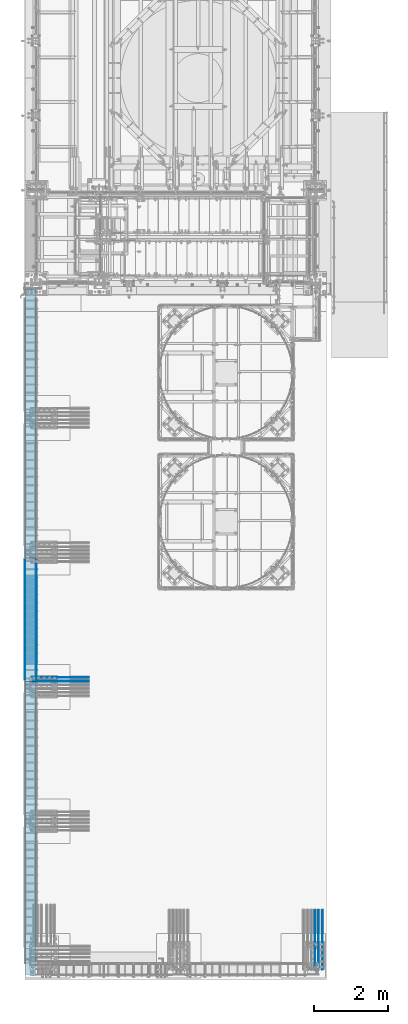
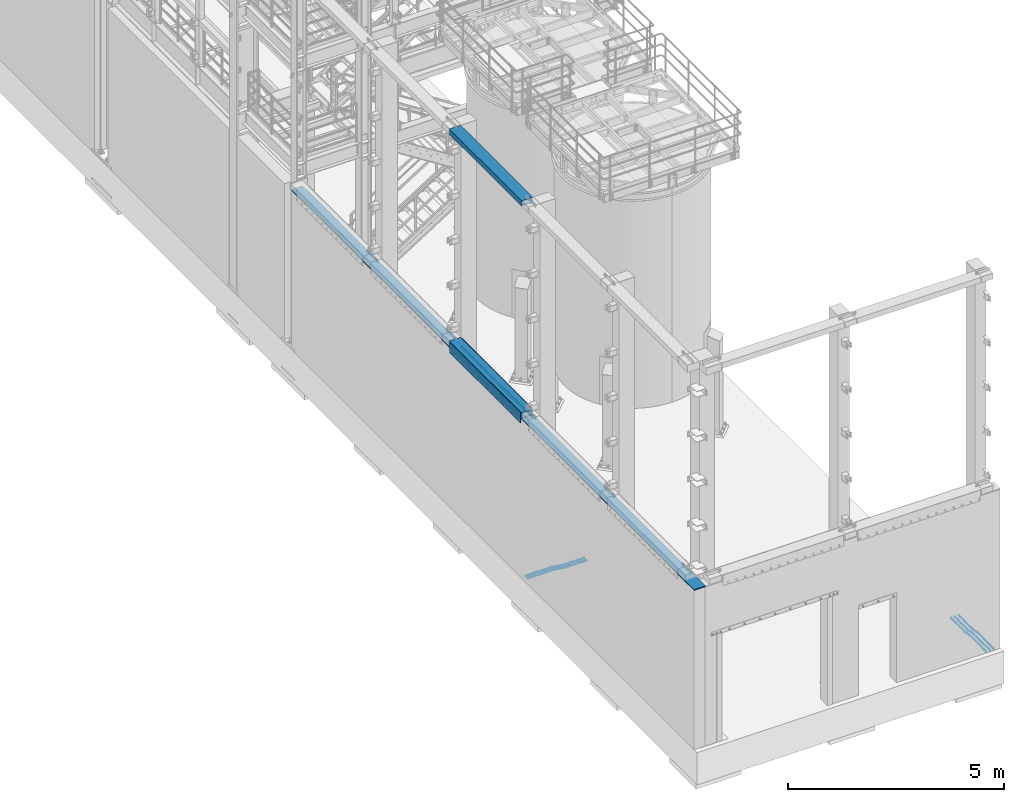
# One storey, part 912 of 1876: 11 beams, 6 elements without a shape of their own.
"""IFC2X3 building model written with IfcOpenShell, lengths in millimetres."""

from ifc_helpers import new_model, si_unit, frame, origin_with_axes, place, context, subcontext, project, spatial, faceted_brep, material, type_object, element, aggregate, save


model = new_model("IFC2X3")

# Units and contexts
model_context = context("Model", 3, precision=1e-05, world=origin_with_axes())
body_context = subcontext(model_context, "Body", "Model", "MODEL_VIEW")
ifc_project = project(units=[si_unit("LENGTHUNIT", "METRE", prefix="MILLI"), si_unit("AREAUNIT", "SQUARE_METRE"), si_unit("VOLUMEUNIT", "CUBIC_METRE"), si_unit("MASSUNIT", "GRAM", prefix="KILO"), si_unit("TIMEUNIT", "SECOND"), si_unit("PLANEANGLEUNIT", "RADIAN"), si_unit("SOLIDANGLEUNIT", "STERADIAN"), si_unit("THERMODYNAMICTEMPERATUREUNIT", "DEGREE_CELSIUS"), si_unit("LUMINOUSINTENSITYUNIT", "LUMEN")], contexts=[model_context])

# Site, building, storey
site_placement = place(None, origin_with_axes())
site = spatial("IfcSite", under=ifc_project, at=site_placement, CompositionType="ELEMENT")
building_placement = place(site_placement, origin_with_axes())
building = spatial("IfcBuilding", under=site, at=building_placement, Name="Undefined", CompositionType="ELEMENT")
storey_placement = place(building_placement, origin_with_axes())
storey = spatial("IfcBuildingStorey", under=building, at=storey_placement, Name="Undefined", CompositionType="ELEMENT", Elevation=0.0)

# Assembly, beam
assembly_1_placement = place(storey_placement, origin_with_axes())
assembly_1 = element("IfcElementAssembly", 1, at=assembly_1_placement, inside=storey, Name="BEAM", AssemblyPlace="NOTDEFINED", PredefinedType="RIGID_FRAME")
ifc_material_1 = material()
beam_type_1 = type_object("IfcBeamType", Name="HSS12X6X1/2", PredefinedType="NOTDEFINED")
beam_1_placement = place(assembly_1_placement, frame((-139.7, -17932.4, 10591.8), z_axis=(-1.0, 0.0, 0.0), x_axis=(0.0, 1.0, 0.0)))
beam_1 = element("IfcBeam", 2, at=beam_1_placement, type_object=beam_type_1, material=ifc_material_1, Name="BEAM", ObjectType="HSS12X6X1/2", context=body_context, shape_type="Brep", body=[
    faceted_brep([(0.0, -63.5, -139.7), (0.0, -76.2000000000007, -139.699999999812), (0.0, -76.2000000000007, 139.700000000026), (0.0, -63.5, 139.7), (0.0, 76.2000000000007, 139.700000000026), (0.0, 63.5, 139.7), (12.6999999999734, -76.2000000000007, 152.4), (12.6999999999734, 76.2000000000007, 152.4), (0.0, 76.2000000000007, -139.699999999812), (0.0, 63.5, -139.7), (12.7000000000025, -76.2000000000007, -152.4), (12.7000000000025, 76.2000000000007, -152.4), (3340.1, 76.2000000000007, -152.4), (3340.1, -76.2000000000007, -152.4), (3352.8, -63.5, -139.7), (3352.8, 63.5, -139.7), (3352.8, 76.2000000000007, -139.7), (3352.8, -76.2000000000007, -139.7), (3352.8, -76.2000000000007, 139.7), (3340.1, -76.2000000000007, 152.4), (3340.1, 76.2000000000007, 152.4), (3352.8, 76.2000000000007, 139.7), (3352.8, 63.5, 139.7), (3352.8, -63.5, 139.7)], [[[0, 1, 2, 3]], [[4, 5, 3, 2, 6, 7]], [[8, 9, 5, 4]], [[10, 11, 12, 13]], [[0, 9, 8, 11, 10, 1]], [[9, 0, 14, 15]], [[12, 16, 15, 14, 17, 13]], [[6, 2, 1, 10, 13, 17, 18, 19]], [[7, 6, 19, 20]], [[16, 12, 11, 8, 4, 7, 20, 21]], [[15, 16, 21, 22]], [[5, 9, 15, 22]], [[3, 5, 22, 23]], [[0, 3, 23, 14]], [[17, 14, 23, 18]], [[22, 21, 20, 19, 18, 23]]]),
])
aggregate(assembly_1, [beam_1])

assembly_2_placement = place(storey_placement, origin_with_axes())
assembly_2 = element("IfcElementAssembly", 3, at=assembly_2_placement, inside=storey, Name="BEAM", AssemblyPlace="NOTDEFINED", PredefinedType="RIGID_FRAME")
beam_2_placement = place(assembly_2_placement, frame((-139.7, -17932.4, 4597.4), z_axis=(-1.0, 0.0, 0.0), x_axis=(0.0, 1.0, 0.0)))
beam_2 = element("IfcBeam", 4, at=beam_2_placement, type_object=beam_type_1, material=ifc_material_1, Name="BEAM", ObjectType="HSS12X6X1/2", context=body_context, shape_type="Brep", body=[
    faceted_brep([(0.0, -63.5, 139.7), (0.0, 63.5, 139.7), (3352.8, 63.5, 139.7), (3352.8, -63.5, 139.7), (0.0, 76.2000000000007, -139.699999999812), (0.0, 63.5, -139.7), (0.0, 76.2000000000007, 139.700000000026), (0.0, -63.5, -139.7), (12.6998385541701, 76.2000000000007, -152.4), (12.6998385541701, -76.2000000000007, -152.4), (0.0, -76.2000000000007, -139.699999999812), (0.0, -76.2000000000007, 139.700000000026), (12.6999999999734, -76.2000000000007, 152.4), (12.6999999999734, 76.2000000000007, 152.4), (3340.1, -76.2000000000007, 152.4), (3340.1, 76.2000000000007, 152.4), (3352.8, 76.2000000000007, 139.7), (3352.8, -76.2000000000007, 139.7), (3352.8, -76.2000000000007, -139.7), (3352.8, -63.5, -139.7), (3352.8, 63.5, -139.7), (3352.8, 76.2000000000007, -139.7), (3340.10010842724, 76.1999999999998, -152.4), (3340.10010842724, -76.1999999999998, -152.4)], [[[0, 1, 2, 3]], [[4, 5, 1, 6]], [[7, 5, 4, 8, 9, 10]], [[7, 10, 11, 0]], [[6, 1, 0, 11, 12, 13]], [[13, 12, 14, 15]], [[2, 16, 15, 14, 17, 3]], [[18, 19, 3, 17]], [[7, 0, 3, 19]], [[5, 7, 19, 20]], [[1, 5, 20, 2]], [[20, 21, 16, 2]], [[15, 16, 21, 22, 8, 4, 6, 13]], [[22, 23, 9, 8]], [[10, 9, 23, 18, 17, 14, 12, 11]], [[22, 21, 20, 19, 18, 23]]]),
])

assembly_3_placement = place(storey_placement, origin_with_axes())
assembly_3 = element("IfcElementAssembly", 5, at=assembly_3_placement, inside=storey, Name="PLATE", AssemblyPlace="NOTDEFINED", PredefinedType="RIGID_FRAME")
ifc_material_2 = material(Name="STEEL/A36")
beam_type_2 = type_object("IfcBeamType", PredefinedType="NOTDEFINED")
beam_3_placement = place(assembly_3_placement, frame((8.73150000000262, -14617.7, 4432.3), z_axis=(0.0, 0.0, 1.0), x_axis=(0.0, -1.0, 0.0)))
beam_3 = element("IfcBeam", 6, at=beam_3_placement, type_object=beam_type_2, material=ifc_material_2, Name="PLATE", context=body_context, shape_type="Brep", body=[
    faceted_brep([(0.0, 3.969, -38.1000000000004), (0.0, 3.969, 38.1000000000004), (3276.6, 3.96900000000096, 38.1000000000004), (3276.6, 3.96900000000096, -38.1000000000004), (0.0, -3.969, 38.1000000000004), (3276.6, -3.96900000000096, 38.1000000000004), (0.0, -3.969, -38.1000000000004), (3276.6, -3.96900000000096, -38.1000000000004)], [[[0, 1, 2, 3]], [[1, 4, 5, 2]], [[4, 6, 7, 5]], [[6, 0, 3, 7]], [[5, 7, 3, 2]], [[6, 4, 1, 0]]]),
])

# Beam
beam_type_3 = type_object("IfcBeamType", PredefinedType="NOTDEFINED")
beam_4_placement = place(assembly_2_placement, frame((-298.450000000003, -14617.7, 4521.2), z_axis=(0.0, 0.0, 1.0), x_axis=(0.0, -1.0, 0.0)))
beam_4 = element("IfcBeam", 7, at=beam_4_placement, type_object=beam_type_3, material=ifc_material_2, Name="PLATE", context=body_context, shape_type="Brep", body=[
    faceted_brep([(0.0, 6.35000000000002, -152.4), (0.0, 6.35000000000002, 152.4), (3276.6, 6.35000000000002, 152.4), (3276.6, 6.35000000000002, -152.4), (0.0, -6.35000000000002, 152.4), (3276.6, -6.35000000000002, 152.4), (0.0, -6.35000000000002, -152.4), (3276.6, -6.35000000000002, -152.4)], [[[0, 1, 2, 3]], [[1, 4, 5, 2]], [[4, 6, 7, 5]], [[6, 0, 3, 7]], [[5, 7, 3, 2]], [[6, 4, 1, 0]]]),
])

aggregate(assembly_2, [beam_4, beam_2])

beam_5_placement = place(assembly_3_placement, frame((19.0500000000011, -14617.7, 4521.2), z_axis=(0.0, 0.0, 1.0), x_axis=(0.0, -1.0, 0.0)))
beam_5 = element("IfcBeam", 8, at=beam_5_placement, type_object=beam_type_3, material=ifc_material_2, Name="PLATE", context=body_context, shape_type="Brep", body=[
    faceted_brep([(0.0, 6.35000000000002, -152.4), (0.0, 6.35000000000002, 152.4), (3276.6, 6.35000000000002, 152.4), (3276.6, 6.35000000000002, -152.4), (0.0, -6.35000000000002, 152.4), (3276.6, -6.35000000000002, 152.4), (0.0, -6.35000000000002, -152.4), (3276.6, -6.35000000000002, -152.4)], [[[0, 1, 2, 3]], [[1, 4, 5, 2]], [[4, 6, 7, 5]], [[6, 0, 3, 7]], [[5, 7, 3, 2]], [[6, 4, 1, 0]]]),
])

aggregate(assembly_3, [beam_3, beam_5])

# Assembly, beams
assembly_4_placement = place(storey_placement, origin_with_axes())
assembly_4 = element("IfcElementAssembly", 9, at=assembly_4_placement, inside=storey, Name="PLATE", AssemblyPlace="NOTDEFINED", PredefinedType="RIGID_FRAME")
ifc_material_3 = material(Name="STEEL/A706-GR.60")
beam_type_4 = type_object("IfcBeamType", Name="5 REBAR", PredefinedType="NOTDEFINED")
beam_6_placement = place(assembly_4_placement, frame((7802.5625, -25781.0, -71.4374999999993), z_axis=(-1.0, 0.0, 0.0), x_axis=(0.0, 1.0, 0.0)))
beam_6 = element("IfcBeam", 10, at=beam_6_placement, type_object=beam_type_4, material=ifc_material_3, Name="REBAR", ObjectType="5 REBAR", context=body_context, shape_type="Brep", body=[
    faceted_brep([(0.0, -7.9375, 0.0), (0.0, -5.61266007566822, -5.61266007566883), (760.672013570867, -5.61266007566822, -5.61266007566837), (760.672013570867, -7.9375, 0.0), (0.0, 0.0, -7.9375), (760.672013570867, 0.0, -7.9375), (0.0, 5.61266007566822, -5.61266007566883), (760.672013570867, 5.61266007566822, -5.61266007566837), (0.0, 7.9375, 0.0), (760.672013570867, 7.9375, 0.0), (0.0, 5.61266007566822, 5.61266007566883), (760.672013570867, 5.61266007566822, 5.61266007566837), (0.0, 0.0, 7.9375), (760.672013570867, 0.0, 7.9375), (0.0, -5.61266007566822, 5.61266007566883), (760.672013570867, -5.61266007566822, 5.61266007566837), (762.585579012299, -5.61266007566822, -5.61266007566837), (762.828108499445, -7.9375, 0.0), (762.000061035156, 0.0, -7.9375), (761.414543058014, 5.61266007566822, -5.61266007566837), (761.172013570867, 7.9375, 0.0), (761.414543058014, 5.61266007566822, 5.61266007566837), (762.000061035156, 0.0, 7.9375), (762.585579012299, -5.61266007566822, 5.61266007566837), (764.4579427221, -5.21770838638834, -5.61266007566837), (764.937779698426, -7.49249126611924, 0.0), (763.299513786125, 0.274103293312095, -7.9375), (762.141084850151, 5.76591497301254, -5.61266007566837), (761.661247873824, 8.04069785274343, 0.0), (762.141084850151, 5.76591497301254, 5.61266007566837), (763.299513786125, 0.274103293312095, 7.9375), (764.4579427221, -5.21770838638834, 5.61266007566837), (965.059049427193, 37.096584264048, -5.61266007566837), (965.538886403519, 34.8218013843171, 0.0), (963.900620491218, 42.5883959437484, -7.9375), (962.742191555244, 48.0802076234489, -5.61266007566837), (962.262354578917, 50.3549905031798, 0.0), (962.742191555244, 48.0802076234489, 5.61266007566837), (963.900620491218, 42.5883959437484, 7.9375), (965.059049427193, 37.096584264048, 5.61266007566837), (965.78559121933, 37.2498391613923, -5.61266007566837), (966.028120706476, 34.9249992370605, 0.0), (965.200073242188, 42.8624992370605, -7.9375), (964.614555265045, 48.4751593127288, -5.61266007566837), (964.372025777899, 50.7999992370606, 0.0), (964.614555265045, 48.4751593127288, 5.61266007566837), (965.200073242188, 42.8624992370605, 7.9375), (965.78559121933, 37.2498391613923, 5.61266007566837), (966.528120706476, 37.2498391613923, -5.61266007566837), (966.528120706476, 34.9249992370605, 0.0), (966.528120706476, 42.8624992370605, -7.9375), (966.528120706476, 48.4751593127288, -5.61266007566837), (966.528120706476, 50.7999992370605, 0.0), (966.528120706476, 48.4751593127288, 5.61266007566837), (966.528120706476, 42.8624992370605, 7.9375), (966.528120706476, 37.2498391613923, 5.61266007566837), (1619.25, 37.2498391613923, -5.61266007566837), (1619.25, 34.9249992370605, 0.0), (1619.25, 42.8624992370605, -7.9375), (1619.25, 48.4751593127288, -5.61266007566837), (1619.25, 50.7999992370605, 0.0), (1619.25, 48.4751593127288, 5.61266007566837), (1619.25, 42.8624992370605, 7.9375), (1619.25, 37.2498391613923, 5.61266007566837)], [[[0, 1, 2, 3]], [[1, 4, 5, 2]], [[4, 6, 7, 5]], [[6, 8, 9, 7]], [[8, 10, 11, 9]], [[10, 12, 13, 11]], [[12, 14, 15, 13]], [[14, 0, 3, 15]], [[14, 12, 10, 8, 6, 4, 1, 0]], [[3, 2, 16, 17]], [[2, 5, 18, 16]], [[5, 7, 19, 18]], [[7, 9, 20, 19]], [[9, 11, 21, 20]], [[11, 13, 22, 21]], [[13, 15, 23, 22]], [[15, 3, 17, 23]], [[17, 16, 24, 25]], [[16, 18, 26, 24]], [[18, 19, 27, 26]], [[19, 20, 28, 27]], [[20, 21, 29, 28]], [[21, 22, 30, 29]], [[22, 23, 31, 30]], [[23, 17, 25, 31]], [[25, 24, 32, 33]], [[24, 26, 34, 32]], [[26, 27, 35, 34]], [[27, 28, 36, 35]], [[28, 29, 37, 36]], [[29, 30, 38, 37]], [[30, 31, 39, 38]], [[31, 25, 33, 39]], [[33, 32, 40, 41]], [[32, 34, 42, 40]], [[34, 35, 43, 42]], [[35, 36, 44, 43]], [[36, 37, 45, 44]], [[37, 38, 46, 45]], [[38, 39, 47, 46]], [[39, 33, 41, 47]], [[41, 40, 48, 49]], [[40, 42, 50, 48]], [[42, 43, 51, 50]], [[43, 44, 52, 51]], [[44, 45, 53, 52]], [[45, 46, 54, 53]], [[46, 47, 55, 54]], [[47, 41, 49, 55]], [[49, 48, 56, 57]], [[48, 50, 58, 56]], [[50, 51, 59, 58]], [[51, 52, 60, 59]], [[52, 53, 61, 60]], [[53, 54, 62, 61]], [[54, 55, 63, 62]], [[55, 49, 57, 63]], [[58, 59, 60, 61, 62, 63, 57, 56]]]),
])
beam_7_placement = place(assembly_4_placement, frame((7694.6125, -25781.0, -71.4374999999993), z_axis=(-1.0, 0.0, 0.0), x_axis=(0.0, 1.0, 0.0)))
beam_7 = element("IfcBeam", 11, at=beam_7_placement, type_object=beam_type_4, material=ifc_material_3, Name="REBAR", ObjectType="5 REBAR", context=body_context, shape_type="Brep", body=[
    faceted_brep([(0.0, -7.9375, 0.0), (0.0, -5.61266007566822, -5.61266007566883), (760.672013570867, -5.61266007566822, -5.61266007566837), (760.672013570867, -7.9375, 0.0), (0.0, 0.0, -7.9375), (760.672013570867, 0.0, -7.9375), (0.0, 5.61266007566822, -5.61266007566883), (760.672013570867, 5.61266007566822, -5.61266007566837), (0.0, 7.9375, 0.0), (760.672013570867, 7.9375, 0.0), (0.0, 5.61266007566822, 5.61266007566883), (760.672013570867, 5.61266007566822, 5.61266007566837), (0.0, 0.0, 7.9375), (760.672013570867, 0.0, 7.9375), (0.0, -5.61266007566822, 5.61266007566883), (760.672013570867, -5.61266007566822, 5.61266007566837), (762.585579012299, -5.61266007566822, -5.61266007566837), (762.828108499445, -7.9375, 0.0), (762.000061035156, 0.0, -7.9375), (761.414543058014, 5.61266007566822, -5.61266007566837), (761.172013570867, 7.9375, 0.0), (761.414543058014, 5.61266007566822, 5.61266007566837), (762.000061035156, 0.0, 7.9375), (762.585579012299, -5.61266007566822, 5.61266007566837), (764.4579427221, -5.21770838638834, -5.61266007566837), (764.937779698426, -7.49249126611924, 0.0), (763.299513786125, 0.274103293312095, -7.9375), (762.141084850151, 5.76591497301254, -5.61266007566837), (761.661247873824, 8.04069785274343, 0.0), (762.141084850151, 5.76591497301254, 5.61266007566837), (763.299513786125, 0.274103293312095, 7.9375), (764.4579427221, -5.21770838638834, 5.61266007566837), (965.059049427193, 37.096584264048, -5.61266007566837), (965.538886403519, 34.8218013843171, 0.0), (963.900620491218, 42.5883959437484, -7.9375), (962.742191555244, 48.0802076234489, -5.61266007566837), (962.262354578917, 50.3549905031798, 0.0), (962.742191555244, 48.0802076234489, 5.61266007566837), (963.900620491218, 42.5883959437484, 7.9375), (965.059049427193, 37.096584264048, 5.61266007566837), (965.78559121933, 37.2498391613923, -5.61266007566837), (966.028120706476, 34.9249992370605, 0.0), (965.200073242188, 42.8624992370605, -7.9375), (964.614555265045, 48.4751593127288, -5.61266007566837), (964.372025777899, 50.7999992370606, 0.0), (964.614555265045, 48.4751593127288, 5.61266007566837), (965.200073242188, 42.8624992370605, 7.9375), (965.78559121933, 37.2498391613923, 5.61266007566837), (966.528120706476, 37.2498391613923, -5.61266007566837), (966.528120706476, 34.9249992370605, 0.0), (966.528120706476, 42.8624992370605, -7.9375), (966.528120706476, 48.4751593127288, -5.61266007566837), (966.528120706476, 50.7999992370605, 0.0), (966.528120706476, 48.4751593127288, 5.61266007566837), (966.528120706476, 42.8624992370605, 7.9375), (966.528120706476, 37.2498391613923, 5.61266007566837), (1619.25, 37.2498391613923, -5.61266007566837), (1619.25, 34.9249992370605, 0.0), (1619.25, 42.8624992370605, -7.9375), (1619.25, 48.4751593127288, -5.61266007566837), (1619.25, 50.7999992370605, 0.0), (1619.25, 48.4751593127288, 5.61266007566837), (1619.25, 42.8624992370605, 7.9375), (1619.25, 37.2498391613923, 5.61266007566837)], [[[0, 1, 2, 3]], [[1, 4, 5, 2]], [[4, 6, 7, 5]], [[6, 8, 9, 7]], [[8, 10, 11, 9]], [[10, 12, 13, 11]], [[12, 14, 15, 13]], [[14, 0, 3, 15]], [[14, 12, 10, 8, 6, 4, 1, 0]], [[3, 2, 16, 17]], [[2, 5, 18, 16]], [[5, 7, 19, 18]], [[7, 9, 20, 19]], [[9, 11, 21, 20]], [[11, 13, 22, 21]], [[13, 15, 23, 22]], [[15, 3, 17, 23]], [[17, 16, 24, 25]], [[16, 18, 26, 24]], [[18, 19, 27, 26]], [[19, 20, 28, 27]], [[20, 21, 29, 28]], [[21, 22, 30, 29]], [[22, 23, 31, 30]], [[23, 17, 25, 31]], [[25, 24, 32, 33]], [[24, 26, 34, 32]], [[26, 27, 35, 34]], [[27, 28, 36, 35]], [[28, 29, 37, 36]], [[29, 30, 38, 37]], [[30, 31, 39, 38]], [[31, 25, 33, 39]], [[33, 32, 40, 41]], [[32, 34, 42, 40]], [[34, 35, 43, 42]], [[35, 36, 44, 43]], [[36, 37, 45, 44]], [[37, 38, 46, 45]], [[38, 39, 47, 46]], [[39, 33, 41, 47]], [[41, 40, 48, 49]], [[40, 42, 50, 48]], [[42, 43, 51, 50]], [[43, 44, 52, 51]], [[44, 45, 53, 52]], [[45, 46, 54, 53]], [[46, 47, 55, 54]], [[47, 41, 49, 55]], [[49, 48, 56, 57]], [[48, 50, 58, 56]], [[50, 51, 59, 58]], [[51, 52, 60, 59]], [[52, 53, 61, 60]], [[53, 54, 62, 61]], [[54, 55, 63, 62]], [[55, 49, 57, 63]], [[58, 59, 60, 61, 62, 63, 57, 56]]]),
])
beam_8_placement = place(assembly_4_placement, frame((7596.18750813802, -25781.0, -71.4374999999993), z_axis=(-1.0, 0.0, 0.0), x_axis=(0.0, 1.0, 0.0)))
beam_8 = element("IfcBeam", 12, at=beam_8_placement, type_object=beam_type_4, material=ifc_material_3, Name="REBAR", ObjectType="5 REBAR", context=body_context, shape_type="Brep", body=[
    faceted_brep([(0.0, -7.9375, 0.0), (0.0, -5.61266007566822, -5.61266007566883), (760.672013570867, -5.61266007566822, -5.61266007566837), (760.672013570867, -7.9375, 0.0), (0.0, 0.0, -7.9375), (760.672013570867, 0.0, -7.9375), (0.0, 5.61266007566822, -5.61266007566883), (760.672013570867, 5.61266007566822, -5.61266007566837), (0.0, 7.9375, 0.0), (760.672013570867, 7.9375, 0.0), (0.0, 5.61266007566822, 5.61266007566883), (760.672013570867, 5.61266007566822, 5.61266007566837), (0.0, 0.0, 7.9375), (760.672013570867, 0.0, 7.9375), (0.0, -5.61266007566822, 5.61266007566883), (760.672013570867, -5.61266007566822, 5.61266007566837), (762.585579012299, -5.61266007566822, -5.61266007566837), (762.828108499445, -7.9375, 0.0), (762.000061035156, 0.0, -7.9375), (761.414543058014, 5.61266007566822, -5.61266007566837), (761.172013570867, 7.9375, 0.0), (761.414543058014, 5.61266007566822, 5.61266007566837), (762.000061035156, 0.0, 7.9375), (762.585579012299, -5.61266007566822, 5.61266007566837), (764.4579427221, -5.21770838638834, -5.61266007566837), (764.937779698426, -7.49249126611924, 0.0), (763.299513786125, 0.274103293312095, -7.9375), (762.141084850151, 5.76591497301254, -5.61266007566837), (761.661247873824, 8.04069785274343, 0.0), (762.141084850151, 5.76591497301254, 5.61266007566837), (763.299513786125, 0.274103293312095, 7.9375), (764.4579427221, -5.21770838638834, 5.61266007566837), (965.059049427193, 37.096584264048, -5.61266007566837), (965.538886403519, 34.8218013843171, 0.0), (963.900620491218, 42.5883959437484, -7.9375), (962.742191555244, 48.0802076234489, -5.61266007566837), (962.262354578917, 50.3549905031798, 0.0), (962.742191555244, 48.0802076234489, 5.61266007566837), (963.900620491218, 42.5883959437484, 7.9375), (965.059049427193, 37.096584264048, 5.61266007566837), (965.78559121933, 37.2498391613923, -5.61266007566837), (966.028120706476, 34.9249992370605, 0.0), (965.200073242188, 42.8624992370605, -7.9375), (964.614555265045, 48.4751593127288, -5.61266007566837), (964.372025777899, 50.7999992370606, 0.0), (964.614555265045, 48.4751593127288, 5.61266007566837), (965.200073242188, 42.8624992370605, 7.9375), (965.78559121933, 37.2498391613923, 5.61266007566837), (966.528120706476, 37.2498391613923, -5.61266007566837), (966.528120706476, 34.9249992370605, 0.0), (966.528120706476, 42.8624992370605, -7.9375), (966.528120706476, 48.4751593127288, -5.61266007566837), (966.528120706476, 50.7999992370605, 0.0), (966.528120706476, 48.4751593127288, 5.61266007566837), (966.528120706476, 42.8624992370605, 7.9375), (966.528120706476, 37.2498391613923, 5.61266007566837), (1619.25, 37.2498391613923, -5.61266007566837), (1619.25, 34.9249992370605, 0.0), (1619.25, 42.8624992370605, -7.9375), (1619.25, 48.4751593127288, -5.61266007566837), (1619.25, 50.7999992370605, 0.0), (1619.25, 48.4751593127288, 5.61266007566837), (1619.25, 42.8624992370605, 7.9375), (1619.25, 37.2498391613923, 5.61266007566837)], [[[0, 1, 2, 3]], [[1, 4, 5, 2]], [[4, 6, 7, 5]], [[6, 8, 9, 7]], [[8, 10, 11, 9]], [[10, 12, 13, 11]], [[12, 14, 15, 13]], [[14, 0, 3, 15]], [[14, 12, 10, 8, 6, 4, 1, 0]], [[3, 2, 16, 17]], [[2, 5, 18, 16]], [[5, 7, 19, 18]], [[7, 9, 20, 19]], [[9, 11, 21, 20]], [[11, 13, 22, 21]], [[13, 15, 23, 22]], [[15, 3, 17, 23]], [[17, 16, 24, 25]], [[16, 18, 26, 24]], [[18, 19, 27, 26]], [[19, 20, 28, 27]], [[20, 21, 29, 28]], [[21, 22, 30, 29]], [[22, 23, 31, 30]], [[23, 17, 25, 31]], [[25, 24, 32, 33]], [[24, 26, 34, 32]], [[26, 27, 35, 34]], [[27, 28, 36, 35]], [[28, 29, 37, 36]], [[29, 30, 38, 37]], [[30, 31, 39, 38]], [[31, 25, 33, 39]], [[33, 32, 40, 41]], [[32, 34, 42, 40]], [[34, 35, 43, 42]], [[35, 36, 44, 43]], [[36, 37, 45, 44]], [[37, 38, 46, 45]], [[38, 39, 47, 46]], [[39, 33, 41, 47]], [[41, 40, 48, 49]], [[40, 42, 50, 48]], [[42, 43, 51, 50]], [[43, 44, 52, 51]], [[44, 45, 53, 52]], [[45, 46, 54, 53]], [[46, 47, 55, 54]], [[47, 41, 49, 55]], [[49, 48, 56, 57]], [[48, 50, 58, 56]], [[50, 51, 59, 58]], [[51, 52, 60, 59]], [[52, 53, 61, 60]], [[53, 54, 62, 61]], [[54, 55, 63, 62]], [[55, 49, 57, 63]], [[58, 59, 60, 61, 62, 63, 57, 56]]]),
])
aggregate(assembly_4, [beam_6, beam_7, beam_8])

assembly_5_placement = place(storey_placement, origin_with_axes())
assembly_5 = element("IfcElementAssembly", 13, at=assembly_5_placement, inside=storey, Name="PLATE", AssemblyPlace="NOTDEFINED", PredefinedType="RIGID_FRAME")
beam_9_placement = place(assembly_5_placement, frame((-123.825012207033, -17932.399991862, -58.7375000000029), z_axis=(0.0, 1.0, 0.0), x_axis=(1.0, 0.0, 0.0)))
beam_9 = element("IfcBeam", 14, at=beam_9_placement, type_object=beam_type_4, material=ifc_material_3, Name="REBAR", ObjectType="5 REBAR", context=body_context, shape_type="Brep", body=[
    faceted_brep([(0.0, -7.9375, 0.0), (0.0, -5.61266007566822, -5.61266007566883), (710.034986674476, -5.61266007566822, -5.61266007566883), (710.034986674476, -7.9375, 0.0), (0.0, 0.0, -7.9375), (710.034986674476, 0.0, -7.9375), (0.0, 5.61266007566822, -5.61266007566883), (710.034986674476, 5.61266007566822, -5.61266007566883), (0.0, 7.9375, 0.0), (710.034986674476, 7.9375, 0.0), (0.0, 5.61266007566822, 5.61266007566883), (710.034986674476, 5.61266007566822, 5.61266007566883), (0.0, 0.0, 7.9375), (710.034986674476, 0.0, 7.9375), (0.0, -5.61266007566822, 5.61266007566883), (710.034986674476, -5.61266007566822, 5.61266007566883), (711.670256270764, -5.61266007566822, -5.61266007566883), (711.865037739587, -7.9375, 0.0), (711.200012207031, 0.0, -7.9375), (710.729768143299, 5.61266007566822, -5.61266007566883), (710.534986674476, 7.9375, 0.0), (710.729768143299, 5.61266007566822, 5.61266007566883), (711.200012207031, 0.0, 7.9375), (711.670256270764, -5.61266007566822, 5.61266007566883), (713.282728188834, -5.34055537895146, -5.61266007566883), (713.669575632193, -7.63298416286913, 0.0), (712.34879584451, 0.193857281957023, -7.9375), (711.414863500185, 5.72826994286551, -5.61266007566883), (711.028016056827, 8.02069872678318, 0.0), (711.414863500185, 5.72826994286551, 5.61266007566883), (712.34879584451, 0.193857281957023, 7.9375), (713.282728188834, -5.34055537895146, 5.61266007566883), (964.985099878721, 37.1342292941951, -5.61266007566883), (965.371947322079, 34.8418005102774, 0.0), (964.051167534397, 42.6686419551035, -7.9375), (963.117235190072, 48.203054616012, -5.61266007566883), (962.730387746714, 50.4954833999297, 0.0), (963.117235190072, 48.203054616012, 5.61266007566883), (964.051167534397, 42.6686419551035, 7.9375), (964.985099878721, 37.1342292941951, 5.61266007566883), (965.670195235607, 37.2498391613923, -5.61266007566883), (965.864976704431, 34.9249992370606, 0.0), (965.199951171875, 42.8624992370605, -7.9375), (964.729707108143, 48.4751593127287, -5.61266007566883), (964.534925639319, 50.7999992370605, 0.0), (964.729707108143, 48.4751593127287, 5.61266007566883), (965.199951171875, 42.8624992370605, 7.9375), (965.670195235607, 37.2498391613923, 5.61266007566883), (966.36497670443, 37.2498391613923, -5.61266007566883), (966.36497670443, 34.9249992370605, 0.0), (966.36497670443, 42.8624992370605, -7.9375), (966.36497670443, 48.4751593127288, -5.61266007566883), (966.36497670443, 50.7999992370605, 0.0), (966.36497670443, 48.4751593127288, 5.61266007566883), (966.36497670443, 42.8624992370605, 7.9375), (966.36497670443, 37.2498391613923, 5.61266007566883), (1566.86254882812, 37.2498391613923, -5.61266007566883), (1566.86254882812, 34.9249992370605, 0.0), (1566.86254882812, 42.8624992370605, -7.9375), (1566.86254882812, 48.4751593127288, -5.61266007566883), (1566.86254882812, 50.7999992370605, 0.0), (1566.86254882812, 48.4751593127288, 5.61266007566883), (1566.86254882812, 42.8624992370605, 7.9375), (1566.86254882812, 37.2498391613923, 5.61266007566883)], [[[0, 1, 2, 3]], [[1, 4, 5, 2]], [[4, 6, 7, 5]], [[6, 8, 9, 7]], [[8, 10, 11, 9]], [[10, 12, 13, 11]], [[12, 14, 15, 13]], [[14, 0, 3, 15]], [[14, 12, 10, 8, 6, 4, 1, 0]], [[3, 2, 16, 17]], [[2, 5, 18, 16]], [[5, 7, 19, 18]], [[7, 9, 20, 19]], [[9, 11, 21, 20]], [[11, 13, 22, 21]], [[13, 15, 23, 22]], [[15, 3, 17, 23]], [[17, 16, 24, 25]], [[16, 18, 26, 24]], [[18, 19, 27, 26]], [[19, 20, 28, 27]], [[20, 21, 29, 28]], [[21, 22, 30, 29]], [[22, 23, 31, 30]], [[23, 17, 25, 31]], [[25, 24, 32, 33]], [[24, 26, 34, 32]], [[26, 27, 35, 34]], [[27, 28, 36, 35]], [[28, 29, 37, 36]], [[29, 30, 38, 37]], [[30, 31, 39, 38]], [[31, 25, 33, 39]], [[33, 32, 40, 41]], [[32, 34, 42, 40]], [[34, 35, 43, 42]], [[35, 36, 44, 43]], [[36, 37, 45, 44]], [[37, 38, 46, 45]], [[38, 39, 47, 46]], [[39, 33, 41, 47]], [[41, 40, 48, 49]], [[40, 42, 50, 48]], [[42, 43, 51, 50]], [[43, 44, 52, 51]], [[44, 45, 53, 52]], [[45, 46, 54, 53]], [[46, 47, 55, 54]], [[47, 41, 49, 55]], [[49, 48, 56, 57]], [[48, 50, 58, 56]], [[50, 51, 59, 58]], [[51, 52, 60, 59]], [[52, 53, 61, 60]], [[53, 54, 62, 61]], [[54, 55, 63, 62]], [[55, 49, 57, 63]], [[58, 59, 60, 61, 62, 63, 57, 56]]]),
])
beam_10_placement = place(assembly_5_placement, frame((-123.825012207033, -17830.8, -58.7374999999993), z_axis=(0.0, 1.0, 0.0), x_axis=(1.0, 0.0, 0.0)))
beam_10 = element("IfcBeam", 15, at=beam_10_placement, type_object=beam_type_4, material=ifc_material_3, Name="REBAR", ObjectType="5 REBAR", context=body_context, shape_type="Brep", body=[
    faceted_brep([(0.0, -7.9375, 0.0), (0.0, -5.61266007566822, -5.61266007566883), (710.034986674476, -5.61266007566822, -5.61266007566883), (710.034986674476, -7.9375, 0.0), (0.0, 0.0, -7.9375), (710.034986674476, 0.0, -7.9375), (0.0, 5.61266007566822, -5.61266007566883), (710.034986674476, 5.61266007566822, -5.61266007566883), (0.0, 7.9375, 0.0), (710.034986674476, 7.9375, 0.0), (0.0, 5.61266007566822, 5.61266007566883), (710.034986674476, 5.61266007566822, 5.61266007566883), (0.0, 0.0, 7.9375), (710.034986674476, 0.0, 7.9375), (0.0, -5.61266007566822, 5.61266007566883), (710.034986674476, -5.61266007566822, 5.61266007566883), (711.670256270764, -5.61266007566822, -5.61266007566883), (711.865037739587, -7.9375, 0.0), (711.200012207031, 0.0, -7.9375), (710.729768143299, 5.61266007566822, -5.61266007566883), (710.534986674476, 7.9375, 0.0), (710.729768143299, 5.61266007566822, 5.61266007566883), (711.200012207031, 0.0, 7.9375), (711.670256270764, -5.61266007566822, 5.61266007566883), (713.282728188834, -5.34055537895146, -5.61266007566883), (713.669575632193, -7.63298416286913, 0.0), (712.34879584451, 0.193857281957023, -7.9375), (711.414863500185, 5.72826994286551, -5.61266007566883), (711.028016056827, 8.02069872678318, 0.0), (711.414863500185, 5.72826994286551, 5.61266007566883), (712.34879584451, 0.193857281957023, 7.9375), (713.282728188834, -5.34055537895146, 5.61266007566883), (964.985099878721, 37.1342292941951, -5.61266007566883), (965.371947322079, 34.8418005102774, 0.0), (964.051167534397, 42.6686419551035, -7.9375), (963.117235190072, 48.203054616012, -5.61266007566883), (962.730387746714, 50.4954833999297, 0.0), (963.117235190072, 48.203054616012, 5.61266007566883), (964.051167534397, 42.6686419551035, 7.9375), (964.985099878721, 37.1342292941951, 5.61266007566883), (965.670195235607, 37.2498391613923, -5.61266007566883), (965.864976704431, 34.9249992370606, 0.0), (965.199951171875, 42.8624992370605, -7.9375), (964.729707108143, 48.4751593127287, -5.61266007566883), (964.534925639319, 50.7999992370605, 0.0), (964.729707108143, 48.4751593127287, 5.61266007566883), (965.199951171875, 42.8624992370605, 7.9375), (965.670195235607, 37.2498391613923, 5.61266007566883), (966.36497670443, 37.2498391613923, -5.61266007566883), (966.36497670443, 34.9249992370605, 0.0), (966.36497670443, 42.8624992370605, -7.9375), (966.36497670443, 48.4751593127288, -5.61266007566883), (966.36497670443, 50.7999992370605, 0.0), (966.36497670443, 48.4751593127288, 5.61266007566883), (966.36497670443, 42.8624992370605, 7.9375), (966.36497670443, 37.2498391613923, 5.61266007566883), (1566.86254882812, 37.2498391613923, -5.61266007566883), (1566.86254882812, 34.9249992370605, 0.0), (1566.86254882812, 42.8624992370605, -7.9375), (1566.86254882812, 48.4751593127288, -5.61266007566883), (1566.86254882812, 50.7999992370605, 0.0), (1566.86254882812, 48.4751593127288, 5.61266007566883), (1566.86254882812, 42.8624992370605, 7.9375), (1566.86254882812, 37.2498391613923, 5.61266007566883)], [[[0, 1, 2, 3]], [[1, 4, 5, 2]], [[4, 6, 7, 5]], [[6, 8, 9, 7]], [[8, 10, 11, 9]], [[10, 12, 13, 11]], [[12, 14, 15, 13]], [[14, 0, 3, 15]], [[14, 12, 10, 8, 6, 4, 1, 0]], [[3, 2, 16, 17]], [[2, 5, 18, 16]], [[5, 7, 19, 18]], [[7, 9, 20, 19]], [[9, 11, 21, 20]], [[11, 13, 22, 21]], [[13, 15, 23, 22]], [[15, 3, 17, 23]], [[17, 16, 24, 25]], [[16, 18, 26, 24]], [[18, 19, 27, 26]], [[19, 20, 28, 27]], [[20, 21, 29, 28]], [[21, 22, 30, 29]], [[22, 23, 31, 30]], [[23, 17, 25, 31]], [[25, 24, 32, 33]], [[24, 26, 34, 32]], [[26, 27, 35, 34]], [[27, 28, 36, 35]], [[28, 29, 37, 36]], [[29, 30, 38, 37]], [[30, 31, 39, 38]], [[31, 25, 33, 39]], [[33, 32, 40, 41]], [[32, 34, 42, 40]], [[34, 35, 43, 42]], [[35, 36, 44, 43]], [[36, 37, 45, 44]], [[37, 38, 46, 45]], [[38, 39, 47, 46]], [[39, 33, 41, 47]], [[41, 40, 48, 49]], [[40, 42, 50, 48]], [[42, 43, 51, 50]], [[43, 44, 52, 51]], [[44, 45, 53, 52]], [[45, 46, 54, 53]], [[46, 47, 55, 54]], [[47, 41, 49, 55]], [[49, 48, 56, 57]], [[48, 50, 58, 56]], [[50, 51, 59, 58]], [[51, 52, 60, 59]], [[52, 53, 61, 60]], [[53, 54, 62, 61]], [[54, 55, 63, 62]], [[55, 49, 57, 63]], [[58, 59, 60, 61, 62, 63, 57, 56]]]),
])
aggregate(assembly_5, [beam_9, beam_10])

# Assembly, beam
assembly_6_placement = place(storey_placement, origin_with_axes())
assembly_6 = element("IfcElementAssembly", 16, at=assembly_6_placement, inside=storey, Name="EXPANSION JOINT", AssemblyPlace="NOTDEFINED", PredefinedType="RIGID_FRAME")
ifc_material_4 = material(Name="STEEL/Steel_Undefined")
beam_type_5 = type_object("IfcBeamType", PredefinedType="NOTDEFINED")
beam_11_placement = place(assembly_6_placement, frame((-139.700000000001, -7267.575, 4508.5), z_axis=(1.0, 0.0, 0.0), x_axis=(0.0, -1.0, 0.0)))
beam_11 = element("IfcBeam", 17, at=beam_11_placement, type_object=beam_type_5, material=ifc_material_4, Name="EXPANSION JOINT", context=body_context, shape_type="Brep", body=[
    faceted_brep([(0.0, 12.6999999999998, -152.400000000001), (0.0, 12.6999999999998, 152.400000000001), (18656.3, 12.6999999999998, 152.4), (18656.3, 12.6999999999998, -152.4), (0.0, -12.6999999999998, 152.400000000001), (18656.3, -12.6999999999998, 152.4), (0.0, -12.6999999999998, -152.400000000001), (18656.3, -12.6999999999998, -152.4)], [[[0, 1, 2, 3]], [[1, 4, 5, 2]], [[4, 6, 7, 5]], [[6, 0, 3, 7]], [[5, 7, 3, 2]], [[6, 4, 1, 0]]]),
])
aggregate(assembly_6, [beam_11])

save(model, "model.ifc")
